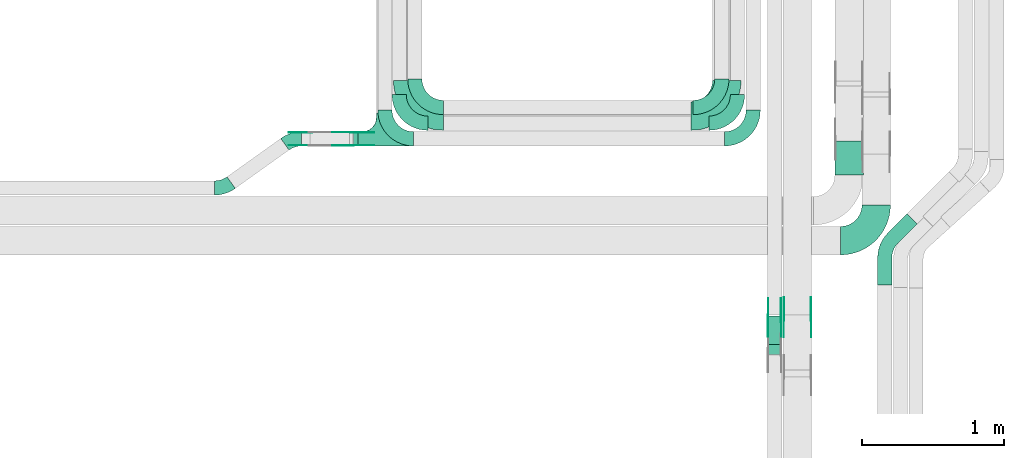
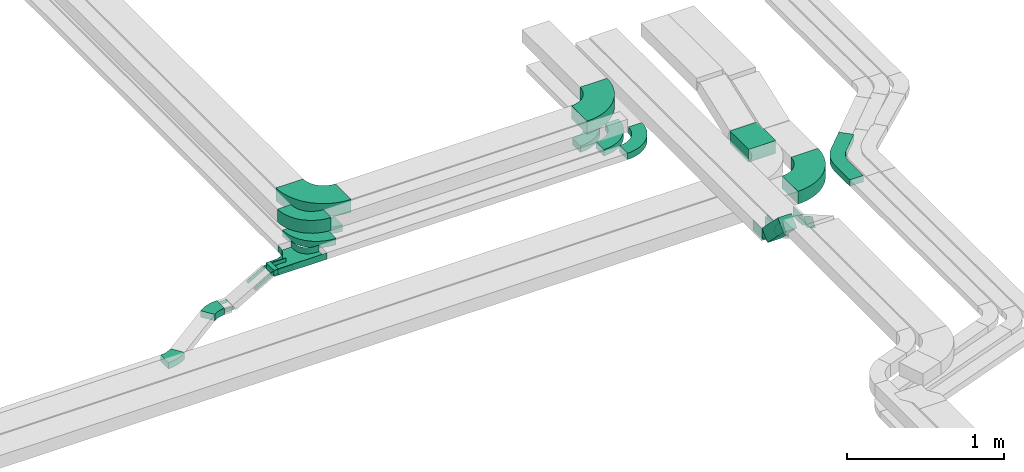
# One storey, part 20 of 23: 27 flow fittings, 3 flow segments.
"""IFC2X3 building model written with IfcOpenShell, lengths in millimetres."""

from ifc_helpers import new_model, entity, si_unit, converted_unit, derived_unit, direction, frame, frame_2d, origin, origin_2d_with_axis, place, context, subcontext, project, spatial, polyline, circle_curve, parameter, trimmed, segment, composite_curve, rectangle, outline, extrude, faceted_brep, source, transform, mapped, material, type_object, type_shapes, element, save


model = new_model("IFC2X3")

# Units and contexts
model_context = context("Model", 3, precision=0.01, world=origin(), true_north=direction((6.12303176911189e-17, 1.0)))
body_context = subcontext(model_context, "Body", "Model", "MODEL_VIEW")
ifc_project = project(units=[si_unit("LENGTHUNIT", "METRE", prefix="MILLI"), si_unit("AREAUNIT", "SQUARE_METRE"), si_unit("VOLUMEUNIT", "CUBIC_METRE"), converted_unit("PLANEANGLEUNIT", "DEGREE", entity("IfcRatioMeasure", 0.0174532925199433), si_unit("PLANEANGLEUNIT", "RADIAN"), dimensions=[0, 0, 0, 0, 0, 0, 0]), si_unit("MASSUNIT", "GRAM", prefix="KILO"), derived_unit("MASSDENSITYUNIT", [(si_unit("MASSUNIT", "GRAM", prefix="KILO"), 1), (si_unit("LENGTHUNIT", "METRE"), -3)]), derived_unit("MOMENTOFINERTIAUNIT", [(si_unit("LENGTHUNIT", "METRE"), 4)]), si_unit("TIMEUNIT", "SECOND"), si_unit("FREQUENCYUNIT", "HERTZ"), si_unit("THERMODYNAMICTEMPERATUREUNIT", "DEGREE_CELSIUS"), derived_unit("THERMALTRANSMITTANCEUNIT", [(si_unit("MASSUNIT", "GRAM", prefix="KILO"), 1), (si_unit("THERMODYNAMICTEMPERATUREUNIT", "KELVIN"), -1), (si_unit("TIMEUNIT", "SECOND"), -3)]), derived_unit("VOLUMETRICFLOWRATEUNIT", [(si_unit("LENGTHUNIT", "METRE"), 3), (si_unit("TIMEUNIT", "SECOND"), -1)]), derived_unit("MASSFLOWRATEUNIT", [(si_unit("MASSUNIT", "GRAM", prefix="KILO"), 1), (si_unit("TIMEUNIT", "SECOND"), -1)]), derived_unit("ROTATIONALFREQUENCYUNIT", [(si_unit("TIMEUNIT", "SECOND"), -1)]), si_unit("ELECTRICCURRENTUNIT", "AMPERE"), si_unit("ELECTRICVOLTAGEUNIT", "VOLT"), si_unit("POWERUNIT", "WATT"), si_unit("FORCEUNIT", "NEWTON", prefix="KILO"), si_unit("ILLUMINANCEUNIT", "LUX"), si_unit("LUMINOUSFLUXUNIT", "LUMEN"), si_unit("LUMINOUSINTENSITYUNIT", "CANDELA"), derived_unit("USERDEFINED", [(si_unit("MASSUNIT", "GRAM", prefix="KILO"), -1), (si_unit("LENGTHUNIT", "METRE"), -2), (si_unit("TIMEUNIT", "SECOND"), 3), (si_unit("LUMINOUSFLUXUNIT", "LUMEN"), 1)]), derived_unit("LINEARVELOCITYUNIT", [(si_unit("LENGTHUNIT", "METRE"), 1), (si_unit("TIMEUNIT", "SECOND"), -1)]), si_unit("PRESSUREUNIT", "PASCAL"), derived_unit("USERDEFINED", [(si_unit("LENGTHUNIT", "METRE"), -2), (si_unit("MASSUNIT", "GRAM", prefix="KILO"), 1), (si_unit("TIMEUNIT", "SECOND"), -2)]), derived_unit("LINEARFORCEUNIT", [(si_unit("MASSUNIT", "GRAM", prefix="KILO"), 1), (si_unit("LENGTHUNIT", "METRE"), 1), (si_unit("TIMEUNIT", "SECOND"), -2), (si_unit("LENGTHUNIT", "METRE"), -1)]), derived_unit("PLANARFORCEUNIT", [(si_unit("MASSUNIT", "GRAM", prefix="KILO"), 1), (si_unit("LENGTHUNIT", "METRE"), 1), (si_unit("TIMEUNIT", "SECOND"), -2), (si_unit("LENGTHUNIT", "METRE"), -2)])], contexts=[model_context])

# Site, building, storey
site_placement = place(None, origin())
site = spatial("IfcSite", under=ifc_project, at=site_placement, CompositionType="ELEMENT")
building_placement = place(site_placement, origin())
building = spatial("IfcBuilding", under=site, at=building_placement, CompositionType="ELEMENT")
storey_placement = place(building_placement, frame((0.0, 0.0, 24000.0)))
storey = spatial("IfcBuildingStorey", under=building, at=storey_placement, CompositionType="ELEMENT", Elevation=24000.0)

# Flow segments
cable_carrier_segment_type = type_object("IfcCableCarrierSegmentType", PredefinedType="CABLETRAYSEGMENT")
flow_segment_1_placement = place(storey_placement, frame((64748.84, 9500.0, 2972.83)))
element("IfcFlowSegment", 1, at=flow_segment_1_placement, inside=storey, type_object=cable_carrier_segment_type, context=body_context, shape_type="SweptSolid", body=[
    extrude(rectangle(XDim=31.2393327962174, YDim=100.000000000001, at=origin_2d_with_axis()), frame((15.62, 50.0, 0.0), z_axis=(0.0, 0.0, 1.0), x_axis=(-1.0, 0.0, 0.0)), (0.0, 0.0, 1.0), 49.9999999999973),
])
flow_segment_2_placement = place(storey_placement, frame((67656.35, 8034.48, 2986.44)))
element("IfcFlowSegment", 2, at=flow_segment_2_placement, inside=storey, type_object=cable_carrier_segment_type, context=body_context, shape_type="SweptSolid", body=[
    extrude(rectangle(XDim=100.000000000001, YDim=99.9999999999946, at=frame_2d((0.0, 0.0), x_axis=(0.0, 1.0))), frame((50.0, 237.93, 35.36), z_axis=(0.0, -0.70710678118652, 0.707106781186575), x_axis=(1.0, 0.0, 0.0)), (0.0, 0.0, 1.0), 286.484201246877),
])
flow_segment_3_placement = place(storey_placement, frame((68128.7, 9295.99, 2805.0)))
element("IfcFlowSegment", 3, at=flow_segment_3_placement, inside=storey, type_object=cable_carrier_segment_type, context=body_context, shape_type="SweptSolid", body=[
    extrude(rectangle(XDim=238.258949212567, YDim=200.000000000007, at=origin_2d_with_axis()), frame((100.0, 119.13, 0.0), z_axis=(0.0, 0.0, 1.0), x_axis=(0.0, 1.0, 0.0)), (0.0, 0.0, 1.0), 100.000000000003),
])

# Flow fittings
ifc_material_1 = material()
cable_carrier_fitting_type_1 = type_object("IfcCableCarrierFittingType", PredefinedType="NOTDEFINED", material=ifc_material_1)
shared_shape_1 = source(origin(), body_context, "Body", "Brep", [
    faceted_brep([(-53.41, -124.12, 25.0), (-50.0, -150.0, 25.0), (-50.0, -180.0, 25.0), (-49.2, -180.0, 25.0), (-49.2, -150.0, 25.0), (-52.63, -123.91, 25.0), (-62.7, -99.6, 25.0), (-78.72, -78.72, 25.0), (-99.6, -62.7, 25.0), (-123.91, -52.63, 25.0), (-150.0, -49.2, 25.0), (-180.0, -49.2, 25.0), (-180.0, -50.0, 25.0), (-150.0, -50.0, 25.0), (-124.12, -53.41, 25.0), (-100.0, -63.4, 25.0), (-79.29, -79.29, 25.0), (-63.4, -100.0, 25.0), (180.0, -50.0, 25.0), (180.0, -49.2, 25.0), (150.0, -49.2, 25.0), (123.91, -52.63, 25.0), (99.6, -62.7, 25.0), (78.72, -78.72, 25.0), (62.7, -99.6, 25.0), (52.63, -123.91, 25.0), (49.2, -150.0, 25.0), (49.2, -180.0, 25.0), (50.0, -180.0, 25.0), (50.0, -150.0, 25.0), (53.41, -124.12, 25.0), (63.4, -100.0, 25.0), (79.29, -79.29, 25.0), (100.0, -63.4, 25.0), (124.12, -53.41, 25.0), (150.0, -50.0, 25.0), (180.0, 49.2, 25.0), (180.0, 50.0, 25.0), (-180.0, 50.0, 25.0), (-180.0, 49.2, 25.0), (-180.0, -50.0, -25.0), (-180.0, 50.0, -25.0), (180.0, 50.0, -25.0), (180.0, -50.0, -25.0), (150.0, -50.0, -25.0), (124.12, -53.41, -25.0), (100.0, -63.4, -25.0), (79.29, -79.29, -25.0), (63.4, -100.0, -25.0), (53.41, -124.12, -25.0), (50.0, -150.0, -25.0), (50.0, -180.0, -25.0), (-50.0, -180.0, -25.0), (-50.0, -150.0, -25.0), (-53.41, -124.12, -25.0), (-63.4, -100.0, -25.0), (-79.29, -79.29, -25.0), (-100.0, -63.4, -25.0), (-124.12, -53.41, -25.0), (-150.0, -50.0, -25.0), (-50.0, -150.0, -24.2), (49.2, -180.0, -24.2), (-49.2, -180.0, -24.2), (-49.2, -150.0, -24.2), (-150.0, -49.2, -24.2), (-180.0, -49.2, -24.2), (180.0, -49.2, -24.2), (150.0, -49.2, -24.2), (-180.0, 49.2, -24.2), (-150.0, -50.0, -24.2), (150.0, -50.0, -24.2), (180.0, 49.2, -24.2), (49.2, -150.0, -24.2), (50.0, -150.0, -24.2), (-123.91, -52.63, -24.2), (-99.6, -62.7, -24.2), (-78.72, -78.72, -24.2), (-62.7, -99.6, -24.2), (-52.63, -123.91, -24.2), (52.63, -123.91, -24.2), (62.7, -99.6, -24.2), (78.72, -78.72, -24.2), (99.6, -62.7, -24.2), (123.91, -52.63, -24.2)], [[[0, 1, 2, 3, 4, 5, 6, 7, 8, 9, 10, 11, 12, 13, 14, 15, 16, 17]], [[18, 19, 20, 21, 22, 23, 24, 25, 26, 27, 28, 29, 30, 31, 32, 33, 34, 35]], [[36, 37, 38, 39]], [[40, 41, 42, 43, 44, 45, 46, 47, 48, 49, 50, 51, 52, 53, 54, 55, 56, 57, 58, 59]], [[2, 1, 60, 53, 52]], [[3, 2, 52, 51, 28, 27, 61, 62]], [[4, 3, 62, 63]], [[11, 10, 64, 65]], [[20, 19, 66, 67]], [[39, 38, 41, 40, 12, 11, 65, 68]], [[13, 12, 40, 59, 69]], [[18, 35, 70, 44, 43]], [[19, 18, 43, 42, 37, 36, 71, 66]], [[27, 26, 72, 61]], [[29, 28, 51, 50, 73]], [[38, 37, 42, 41]], [[36, 39, 68, 71]], [[68, 65, 64, 74, 75, 76, 77, 78, 63, 62, 61, 72, 79, 80, 81, 82, 83, 67, 66, 71]], [[14, 13, 69, 59, 58]], [[58, 57, 15, 14]], [[15, 57, 56, 16]], [[0, 17, 55, 54]], [[0, 54, 53, 60, 1]], [[55, 17, 16, 56]], [[5, 4, 63, 78]], [[6, 5, 78, 77]], [[7, 6, 77, 76]], [[8, 7, 76, 75]], [[9, 8, 75, 74]], [[10, 9, 74, 64]], [[21, 20, 67, 83]], [[22, 21, 83, 82]], [[23, 22, 82, 81]], [[81, 80, 24, 23]], [[24, 80, 79, 25]], [[79, 72, 26, 25]], [[30, 29, 73, 50, 49]], [[31, 30, 49, 48]], [[31, 48, 47, 32]], [[33, 32, 47, 46]], [[45, 34, 33, 46]], [[34, 45, 44, 70, 35]]]),
])
type_shapes(cable_carrier_fitting_type_1, [shared_shape_1])
flow_fitting_1_placement = place(storey_placement, frame((64960.08, 9550.0, 2997.83), z_axis=(0.0, 0.0, 1.0), x_axis=(-1.0, 0.0, 0.0)))
element("IfcFlowFitting", 4, at=flow_fitting_1_placement, inside=storey, type_object=cable_carrier_fitting_type_1, material=ifc_material_1, Name="470_DKC_S5_T", context=body_context, shape_type="MappedRepresentation", body=[
    mapped(shared_shape_1, transform((0.0, 0.0, 0.0), scale=1.0)),
])
cable_carrier_fitting_type_2 = type_object("IfcCableCarrierFittingType", Name="470_DKC_S5_Variable Angle Elbow 0-45:-", PredefinedType="NOTDEFINED", material=ifc_material_1)
shared_shape_2 = source(origin(), body_context, "Body", "SweptSolid", [
    extrude(outline(composite_curve([segment(polyline([(-125.75, -225.25), (-124.75, -225.25)]), True, "CONTINUOUS"), segment(trimmed(circle_curve(frame_2d((-124.75, 124.75), x_axis=(0.0, -1.0)), 350.0), [parameter(0.0)], [parameter(90.0000000000001)], True, "PARAMETER"), True, "CONTINUOUS"), segment(polyline([(225.25, 124.75), (225.25, 125.75)]), True, "CONTINUOUS"), segment(polyline([(225.25, 125.75), (25.25, 125.75)]), True, "CONTINUOUS"), segment(polyline([(25.25, 125.75), (25.25, 124.75)]), True, "CONTINUOUS"), segment(trimmed(circle_curve(frame_2d((-124.75, 124.75), x_axis=(0.0, -1.0)), 150.0), [parameter(0.0)], [parameter(90.0000000000001)], True, "PARAMETER"), False, "CONTINUOUS"), segment(polyline([(-124.75, -25.25), (-125.75, -25.25)]), True, "CONTINUOUS"), segment(polyline([(-125.75, -25.25), (-125.75, -225.25)]), True, "CONTINUOUS")], self_intersect=False)), frame((-125.25, 125.25, -50.0)), (0.0, 0.0, 1.0), 100.0),
])
type_shapes(cable_carrier_fitting_type_2, [shared_shape_2])
flow_fitting_2_placement = place(storey_placement, frame((67370.08, 9710.0, 3237.83)))
element("IfcFlowFitting", 5, at=flow_fitting_2_placement, inside=storey, type_object=cable_carrier_fitting_type_2, material=ifc_material_1, Name="470_DKC_S5_Variable Angle Elbow 0-45:-", ObjectType="470_DKC_S5_Variable Angle Elbow 0-45:-", context=body_context, shape_type="MappedRepresentation", body=[
    mapped(shared_shape_2, transform((0.0, 0.0, 0.0), scale=1.0)),
])
flow_fitting_3_placement = place(storey_placement, frame((65130.08, 9710.0, 3237.83), z_axis=(0.0, 0.0, 1.0), x_axis=(0.0, -1.0, 0.0)))
element("IfcFlowFitting", 6, at=flow_fitting_3_placement, inside=storey, type_object=cable_carrier_fitting_type_2, material=ifc_material_1, Name="470_DKC_S5_Variable Angle Elbow 0-45:-", ObjectType="470_DKC_S5_Variable Angle Elbow 0-45:-", context=body_context, shape_type="MappedRepresentation", body=[
    mapped(shared_shape_2, transform((0.0, 0.0, 0.0), scale=1.0)),
])
flow_fitting_4_placement = place(storey_placement, frame((68419.24, 8834.99, 2855.0)))
element("IfcFlowFitting", 7, at=flow_fitting_4_placement, inside=storey, type_object=cable_carrier_fitting_type_2, material=ifc_material_1, Name="470_DKC_S5_Variable Angle Elbow 0-45:-", ObjectType="470_DKC_S5_Variable Angle Elbow 0-45:-", context=body_context, shape_type="MappedRepresentation", body=[
    mapped(shared_shape_2, transform((0.0, 0.0, 0.0), scale=1.0)),
])
cable_carrier_fitting_type_3 = type_object("IfcCableCarrierFittingType", Name="470_DKC_S5_Variable Angle Elbow 0-45:-", PredefinedType="NOTDEFINED", material=ifc_material_1)
shared_shape_3 = source(origin(), body_context, "Body", "SweptSolid", [
    extrude(outline(composite_curve([segment(polyline([(-100.75, -150.25), (-99.75, -150.25)]), True, "CONTINUOUS"), segment(trimmed(circle_curve(frame_2d((-99.75, 99.75), x_axis=(0.0, -1.0)), 250.0), [parameter(0.0)], [parameter(90.0000000000001)], True, "PARAMETER"), True, "CONTINUOUS"), segment(polyline([(150.25, 99.75), (150.25, 100.75)]), True, "CONTINUOUS"), segment(polyline([(150.25, 100.75), (50.25, 100.75)]), True, "CONTINUOUS"), segment(polyline([(50.25, 100.75), (50.25, 99.75)]), True, "CONTINUOUS"), segment(trimmed(circle_curve(frame_2d((-99.75, 99.75), x_axis=(0.0, -1.0)), 150.0), [parameter(0.0)], [parameter(90.0000000000001)], True, "PARAMETER"), False, "CONTINUOUS"), segment(polyline([(-99.75, -50.25), (-100.75, -50.25)]), True, "CONTINUOUS"), segment(polyline([(-100.75, -50.25), (-100.75, -150.25)]), True, "CONTINUOUS")], self_intersect=False)), frame((-100.25, 100.25, -25.0)), (0.0, 0.0, 1.0), 49.9999999999997),
])
type_shapes(cable_carrier_fitting_type_3, [shared_shape_3])
flow_fitting_5_placement = place(storey_placement, frame((65180.08, 9770.0, 2997.83), z_axis=(0.0, 0.0, 1.0), x_axis=(0.0, -1.0, 0.0)))
element("IfcFlowFitting", 8, at=flow_fitting_5_placement, inside=storey, type_object=cable_carrier_fitting_type_3, material=ifc_material_1, Name="470_DKC_S5_Variable Angle Elbow 0-45:-", ObjectType="470_DKC_S5_Variable Angle Elbow 0-45:-", context=body_context, shape_type="MappedRepresentation", body=[
    mapped(shared_shape_3, transform((0.0, 0.0, 0.0), scale=1.0)),
])
flow_fitting_6_placement = place(storey_placement, frame((67335.53, 9770.0, 2997.83)))
element("IfcFlowFitting", 9, at=flow_fitting_6_placement, inside=storey, type_object=cable_carrier_fitting_type_3, material=ifc_material_1, Name="470_DKC_S5_Variable Angle Elbow 0-45:-", ObjectType="470_DKC_S5_Variable Angle Elbow 0-45:-", context=body_context, shape_type="MappedRepresentation", body=[
    mapped(shared_shape_3, transform((0.0, 0.0, 0.0), scale=1.0)),
])
flow_fitting_7_placement = place(storey_placement, frame((65070.08, 9660.0, 2997.83), z_axis=(0.0, 0.0, 1.0), x_axis=(0.0, -1.0, 0.0)))
element("IfcFlowFitting", 10, at=flow_fitting_7_placement, inside=storey, type_object=cable_carrier_fitting_type_3, material=ifc_material_1, Name="470_DKC_S5_Variable Angle Elbow 0-45:-", ObjectType="470_DKC_S5_Variable Angle Elbow 0-45:-", context=body_context, shape_type="MappedRepresentation", body=[
    mapped(shared_shape_3, transform((0.0, 0.0, 0.0), scale=1.0)),
])
for number, where, name in (
    (11, (67445.53, 9660.0, 2997.83), "470_DKC_S5_Variable Angle Elbow 0-45:-"),
    (12, (67555.53, 9550.0, 2997.83), "470_DKC_S5_Variable Angle Elbow 0-45:-"),
):
    element("IfcFlowFitting", number, at=place(storey_placement, frame(where)), inside=storey, type_object=cable_carrier_fitting_type_3, material=ifc_material_1, Name=name, ObjectType="470_DKC_S5_Variable Angle Elbow 0-45:-", context=body_context, shape_type="MappedRepresentation", body=[
        mapped(shared_shape_3, transform((0.0, 0.0, 0.0), scale=1.0)),
    ])
ifc_material_2 = material(Name="G")
cable_carrier_fitting_type_4 = type_object("IfcCableCarrierFittingType", PredefinedType="NOTDEFINED", material=ifc_material_2)
shared_shape_4 = source(origin(), body_context, "Body", "SweptSolid", [
    extrude(outline(composite_curve([segment(trimmed(circle_curve(frame_2d((-44.59, 0.0), x_axis=(1.0, 0.0)), 12.5), [parameter(90.0000000000007)], [parameter(270.0)], True, "PARAMETER"), True, "CONTINUOUS"), segment(polyline([(-44.59, -12.5), (-33.09, -12.5)]), True, "CONTINUOUS"), segment(polyline([(-33.09, -12.5), (-31.23, -14.5)]), True, "CONTINUOUS"), segment(polyline([(-31.23, -14.5), (108.91, -14.5)]), True, "CONTINUOUS"), segment(polyline([(108.91, -14.5), (108.91, 14.5)]), True, "CONTINUOUS"), segment(polyline([(108.91, 14.5), (-31.23, 14.5)]), True, "CONTINUOUS"), segment(polyline([(-31.23, 14.5), (-33.09, 12.5)]), True, "CONTINUOUS"), segment(polyline([(-33.09, 12.5), (-44.59, 12.5)]), True, "CONTINUOUS")], self_intersect=False)), frame((44.59, 0.0, 0.0), z_axis=(0.0, 0.0, -1.0), x_axis=(1.0, 0.0, 0.0)), (0.0, 0.0, -1.0), 2.0),
])
type_shapes(cable_carrier_fitting_type_4, [shared_shape_4])
flow_fitting_8_placement = place(storey_placement, frame((64740.08, 9504.54, 2997.83), z_axis=(0.0, -1.0, 0.0), x_axis=(-0.866342460673953, 0.0, -0.499450438815904)))
element("IfcFlowFitting", 13, at=flow_fitting_8_placement, inside=storey, type_object=cable_carrier_fitting_type_4, material=ifc_material_2, context=body_context, shape_type="MappedRepresentation", body=[
    mapped(shared_shape_4, transform((0.0, 0.0, 0.0), scale=1.0)),
])
cable_carrier_fitting_type_5 = type_object("IfcCableCarrierFittingType", PredefinedType="NOTDEFINED", material=ifc_material_2)
type_shapes(cable_carrier_fitting_type_5, [shared_shape_4])
for number, where, z_axis, x_axis in (
    (14, (64740.08, 9593.46, 2997.83), (0.0, 1.0, 0.0), (1.0, 0.0, 0.0)),
    (15, (64448.97, 9593.46, 2830.0), (0.0, 1.0, 0.0), (-1.0, 0.0, 0.0)),
):
    element("IfcFlowFitting", number, at=place(storey_placement, frame(where, z_axis=z_axis, x_axis=x_axis)), inside=storey, type_object=cable_carrier_fitting_type_5, material=ifc_material_2, context=body_context, shape_type="MappedRepresentation", body=[
        mapped(shared_shape_4, transform((0.0, 0.0, 0.0), scale=1.0)),
    ])
cable_carrier_fitting_type_6 = type_object("IfcCableCarrierFittingType", PredefinedType="NOTDEFINED", material=ifc_material_2)
shared_shape_5 = source(origin(), body_context, "Body", "SweptSolid", [
    extrude(outline(composite_curve([segment(trimmed(circle_curve(frame_2d((-44.59, 0.0), x_axis=(1.0, 0.0)), 12.5), [parameter(90.0000000000007)], [parameter(270.0)], True, "PARAMETER"), True, "CONTINUOUS"), segment(polyline([(-44.59, -12.5), (-33.09, -12.5)]), True, "CONTINUOUS"), segment(polyline([(-33.09, -12.5), (-31.23, -14.5)]), True, "CONTINUOUS"), segment(polyline([(-31.23, -14.5), (108.91, -14.5)]), True, "CONTINUOUS"), segment(polyline([(108.91, -14.5), (108.91, 14.5)]), True, "CONTINUOUS"), segment(polyline([(108.91, 14.5), (-31.23, 14.5)]), True, "CONTINUOUS"), segment(polyline([(-31.23, 14.5), (-33.09, 12.5)]), True, "CONTINUOUS"), segment(polyline([(-33.09, 12.5), (-44.59, 12.5)]), True, "CONTINUOUS")], self_intersect=False)), frame((44.59, 0.0, 0.0)), (0.0, 0.0, 1.0), 2.0),
])
type_shapes(cable_carrier_fitting_type_6, [shared_shape_5])
flow_fitting_9_placement = place(storey_placement, frame((64740.08, 9595.46, 2997.83), z_axis=(0.0, 1.0, 0.0), x_axis=(-0.866342460673953, 0.0, -0.499450438815904)))
element("IfcFlowFitting", 16, at=flow_fitting_9_placement, inside=storey, type_object=cable_carrier_fitting_type_6, material=ifc_material_2, context=body_context, shape_type="MappedRepresentation", body=[
    mapped(shared_shape_5, transform((0.0, 0.0, 0.0), scale=1.0)),
])
cable_carrier_fitting_type_7 = type_object("IfcCableCarrierFittingType", PredefinedType="NOTDEFINED", material=ifc_material_2)
type_shapes(cable_carrier_fitting_type_7, [shared_shape_5])
for number, where, z_axis, x_axis in (
    (17, (64740.08, 9506.54, 2997.83), (0.0, -1.0, 0.0), (1.0, 0.0, 0.0)),
    (18, (64448.97, 9506.54, 2830.0), (0.0, -1.0, 0.0), (-1.0, 0.0, 0.0)),
):
    element("IfcFlowFitting", number, at=place(storey_placement, frame(where, z_axis=z_axis, x_axis=x_axis)), inside=storey, type_object=cable_carrier_fitting_type_7, material=ifc_material_2, context=body_context, shape_type="MappedRepresentation", body=[
        mapped(shared_shape_5, transform((0.0, 0.0, 0.0), scale=1.0)),
    ])
cable_carrier_fitting_type_8 = type_object("IfcCableCarrierFittingType", Name="470_DKC_S5_Variable Angle Elbow 0-45:-", PredefinedType="NOTDEFINED", material=ifc_material_1)
shared_shape_6 = source(origin(), body_context, "Body", "SweptSolid", [
    extrude(outline(composite_curve([segment(polyline([(-100.75, -150.25), (-99.75, -150.25)]), True, "CONTINUOUS"), segment(trimmed(circle_curve(frame_2d((-99.75, 99.75), x_axis=(0.0, -1.0)), 250.0), [parameter(0.0)], [parameter(90.0000000000001)], True, "PARAMETER"), True, "CONTINUOUS"), segment(polyline([(150.25, 99.75), (150.25, 100.75)]), True, "CONTINUOUS"), segment(polyline([(150.25, 100.75), (50.25, 100.75)]), True, "CONTINUOUS"), segment(polyline([(50.25, 100.75), (50.25, 99.75)]), True, "CONTINUOUS"), segment(trimmed(circle_curve(frame_2d((-99.75, 99.75), x_axis=(0.0, -1.0)), 150.0), [parameter(0.0)], [parameter(90.0000000000001)], True, "PARAMETER"), False, "CONTINUOUS"), segment(polyline([(-99.75, -50.25), (-100.75, -50.25)]), True, "CONTINUOUS"), segment(polyline([(-100.75, -50.25), (-100.75, -150.25)]), True, "CONTINUOUS")], self_intersect=False)), frame((-100.25, 100.25, -50.0)), (0.0, 0.0, 1.0), 100.0),
])
type_shapes(cable_carrier_fitting_type_8, [shared_shape_6])
flow_fitting_10_placement = place(storey_placement, frame((64970.08, 9550.0, 3237.83), z_axis=(0.0, 0.0, 1.0), x_axis=(0.0, -1.0, 0.0)))
element("IfcFlowFitting", 19, at=flow_fitting_10_placement, inside=storey, type_object=cable_carrier_fitting_type_8, material=ifc_material_1, Name="470_DKC_S5_Variable Angle Elbow 0-45:-", ObjectType="470_DKC_S5_Variable Angle Elbow 0-45:-", context=body_context, shape_type="MappedRepresentation", body=[
    mapped(shared_shape_6, transform((0.0, 0.0, 0.0), scale=1.0)),
])
cable_carrier_fitting_type_9 = type_object("IfcCableCarrierFittingType", PredefinedType="NOTDEFINED", material=ifc_material_2)
shared_shape_7 = source(origin(), body_context, "Body", "SweptSolid", [
    extrude(outline(composite_curve([segment(trimmed(circle_curve(frame_2d((-41.47, 0.0), x_axis=(1.0, 0.0)), 25.0), [parameter(90.0000000000007)], [parameter(270.0)], True, "PARAMETER"), True, "CONTINUOUS"), segment(polyline([(-41.47, -25.0), (-29.97, -25.0)]), True, "CONTINUOUS"), segment(polyline([(-29.97, -25.0), (-28.1, -38.5)]), True, "CONTINUOUS"), segment(polyline([(-28.1, -38.5), (99.53, -38.5)]), True, "CONTINUOUS"), segment(polyline([(99.53, -38.5), (99.53, 38.5)]), True, "CONTINUOUS"), segment(polyline([(99.53, 38.5), (-28.1, 38.5)]), True, "CONTINUOUS"), segment(polyline([(-28.1, 38.5), (-29.97, 25.0)]), True, "CONTINUOUS"), segment(polyline([(-29.97, 25.0), (-41.47, 25.0)]), True, "CONTINUOUS")], self_intersect=False)), frame((41.47, 0.0, 0.0), z_axis=(0.0, 0.0, -1.0), x_axis=(1.0, 0.0, 0.0)), (0.0, 0.0, -1.0), 2.0),
])
type_shapes(cable_carrier_fitting_type_9, [shared_shape_7])
flow_fitting_11_placement = place(storey_placement, frame((67770.89, 8298.28, 3005.27), z_axis=(-1.0, 0.0, 0.0), x_axis=(0.0, -0.866025403784327, 0.500000000000193)))
element("IfcFlowFitting", 20, at=flow_fitting_11_placement, inside=storey, type_object=cable_carrier_fitting_type_9, material=ifc_material_2, context=body_context, shape_type="MappedRepresentation", body=[
    mapped(shared_shape_7, transform((0.0, 0.0, 0.0), scale=1.0)),
])
cable_carrier_fitting_type_10 = type_object("IfcCableCarrierFittingType", PredefinedType="NOTDEFINED", material=ifc_material_2)
type_shapes(cable_carrier_fitting_type_10, [shared_shape_7])
flow_fitting_12_placement = place(storey_placement, frame((67959.81, 8298.28, 3005.27), z_axis=(1.0, 0.0, 0.0), x_axis=(0.0, 1.0, 0.0)))
element("IfcFlowFitting", 21, at=flow_fitting_12_placement, inside=storey, type_object=cable_carrier_fitting_type_10, material=ifc_material_2, context=body_context, shape_type="MappedRepresentation", body=[
    mapped(shared_shape_7, transform((0.0, 0.0, 0.0), scale=1.0)),
])
flow_fitting_13_placement = place(storey_placement, frame((67660.89, 8288.93, 3005.27), z_axis=(-1.0, 0.0, 0.0), x_axis=(0.0, -0.707106781186429, 0.707106781186666)))
element("IfcFlowFitting", 22, at=flow_fitting_13_placement, inside=storey, type_object=cable_carrier_fitting_type_9, material=ifc_material_2, context=body_context, shape_type="MappedRepresentation", body=[
    mapped(shared_shape_7, transform((0.0, 0.0, 0.0), scale=1.0)),
])
flow_fitting_14_placement = place(storey_placement, frame((67749.81, 8288.93, 3005.27), z_axis=(1.0, 0.0, 0.0), x_axis=(0.0, 1.0, 0.0)))
element("IfcFlowFitting", 23, at=flow_fitting_14_placement, inside=storey, type_object=cable_carrier_fitting_type_10, material=ifc_material_2, context=body_context, shape_type="MappedRepresentation", body=[
    mapped(shared_shape_7, transform((0.0, 0.0, 0.0), scale=1.0)),
])
cable_carrier_fitting_type_11 = type_object("IfcCableCarrierFittingType", PredefinedType="NOTDEFINED", material=ifc_material_2)
shared_shape_8 = source(origin(), body_context, "Body", "SweptSolid", [
    extrude(outline(composite_curve([segment(trimmed(circle_curve(frame_2d((-41.47, 0.0), x_axis=(1.0, 0.0)), 25.0), [parameter(90.0000000000007)], [parameter(270.0)], True, "PARAMETER"), True, "CONTINUOUS"), segment(polyline([(-41.47, -25.0), (-29.97, -25.0)]), True, "CONTINUOUS"), segment(polyline([(-29.97, -25.0), (-28.1, -38.5)]), True, "CONTINUOUS"), segment(polyline([(-28.1, -38.5), (99.53, -38.5)]), True, "CONTINUOUS"), segment(polyline([(99.53, -38.5), (99.53, 38.5)]), True, "CONTINUOUS"), segment(polyline([(99.53, 38.5), (-28.1, 38.5)]), True, "CONTINUOUS"), segment(polyline([(-28.1, 38.5), (-29.97, 25.0)]), True, "CONTINUOUS"), segment(polyline([(-29.97, 25.0), (-41.47, 25.0)]), True, "CONTINUOUS")], self_intersect=False)), frame((41.47, 0.0, 0.0)), (0.0, 0.0, 1.0), 2.0),
])
type_shapes(cable_carrier_fitting_type_11, [shared_shape_8])
flow_fitting_15_placement = place(storey_placement, frame((67961.81, 8298.28, 3005.27), z_axis=(1.0, 0.0, 0.0), x_axis=(0.0, -0.866025403784327, 0.500000000000193)))
element("IfcFlowFitting", 24, at=flow_fitting_15_placement, inside=storey, type_object=cable_carrier_fitting_type_11, material=ifc_material_2, context=body_context, shape_type="MappedRepresentation", body=[
    mapped(shared_shape_8, transform((0.0, 0.0, 0.0), scale=1.0)),
])
cable_carrier_fitting_type_12 = type_object("IfcCableCarrierFittingType", PredefinedType="NOTDEFINED", material=ifc_material_2)
type_shapes(cable_carrier_fitting_type_12, [shared_shape_8])
flow_fitting_16_placement = place(storey_placement, frame((67772.89, 8298.28, 3005.27), z_axis=(-1.0, 0.0, 0.0), x_axis=(0.0, 1.0, 0.0)))
element("IfcFlowFitting", 25, at=flow_fitting_16_placement, inside=storey, type_object=cable_carrier_fitting_type_12, material=ifc_material_2, context=body_context, shape_type="MappedRepresentation", body=[
    mapped(shared_shape_8, transform((0.0, 0.0, 0.0), scale=1.0)),
])
flow_fitting_17_placement = place(storey_placement, frame((67751.81, 8288.93, 3005.27), z_axis=(1.0, 0.0, 0.0), x_axis=(0.0, -0.707106781186429, 0.707106781186666)))
element("IfcFlowFitting", 26, at=flow_fitting_17_placement, inside=storey, type_object=cable_carrier_fitting_type_11, material=ifc_material_2, context=body_context, shape_type="MappedRepresentation", body=[
    mapped(shared_shape_8, transform((0.0, 0.0, 0.0), scale=1.0)),
])
flow_fitting_18_placement = place(storey_placement, frame((67662.89, 8288.93, 3005.27), z_axis=(-1.0, 0.0, 0.0), x_axis=(0.0, 1.0, 0.0)))
element("IfcFlowFitting", 27, at=flow_fitting_18_placement, inside=storey, type_object=cable_carrier_fitting_type_12, material=ifc_material_2, context=body_context, shape_type="MappedRepresentation", body=[
    mapped(shared_shape_8, transform((0.0, 0.0, 0.0), scale=1.0)),
])
cable_carrier_fitting_type_13 = type_object("IfcCableCarrierFittingType", Name="470_DKC_S5_Variable Angle Elbow 0-45:-", PredefinedType="NOTDEFINED", material=ifc_material_1)
shared_shape_9 = source(origin(), body_context, "Body", "SweptSolid", [
    extrude(outline(composite_curve([segment(polyline([(-59.08, -68.77), (-58.08, -68.77)]), True, "CONTINUOUS"), segment(trimmed(circle_curve(frame_2d((-58.08, 181.23), x_axis=(0.0, -1.0)), 250.0), [parameter(0.0)], [parameter(35.5374827848269)], True, "PARAMETER"), True, "CONTINUOUS"), segment(polyline([(87.23, -22.21), (88.05, -21.62)]), True, "CONTINUOUS"), segment(polyline([(88.05, -21.62), (29.92, 59.75)]), True, "CONTINUOUS"), segment(polyline([(29.92, 59.75), (29.11, 59.17)]), True, "CONTINUOUS"), segment(trimmed(circle_curve(frame_2d((-58.08, 181.23), x_axis=(0.0, -1.0)), 150.0), [parameter(0.0)], [parameter(35.5374827848269)], True, "PARAMETER"), False, "CONTINUOUS"), segment(polyline([(-58.08, 31.23), (-59.08, 31.23)]), True, "CONTINUOUS"), segment(polyline([(-59.08, 31.23), (-59.08, -68.77)]), True, "CONTINUOUS")], self_intersect=False)), frame((-6.02, 18.77, -25.0)), (0.0, 0.0, 1.0), 50.0),
])
type_shapes(cable_carrier_fitting_type_13, [shared_shape_9])
flow_fitting_19_placement = place(storey_placement, frame((64320.48, 9550.0, 2830.0), z_axis=(0.0, 0.0, 1.0), x_axis=(-1.0, 0.0, 0.0)))
element("IfcFlowFitting", 28, at=flow_fitting_19_placement, inside=storey, type_object=cable_carrier_fitting_type_13, material=ifc_material_1, Name="470_DKC_S5_Variable Angle Elbow 0-45:-", ObjectType="470_DKC_S5_Variable Angle Elbow 0-45:-", context=body_context, shape_type="MappedRepresentation", body=[
    mapped(shared_shape_9, transform((0.0, 0.0, 0.0), scale=1.0)),
])
flow_fitting_20_placement = place(storey_placement, frame((63837.46, 9204.99, 2830.0)))
element("IfcFlowFitting", 29, at=flow_fitting_20_placement, inside=storey, type_object=cable_carrier_fitting_type_13, material=ifc_material_1, Name="470_DKC_S5_Variable Angle Elbow 0-45:-", ObjectType="470_DKC_S5_Variable Angle Elbow 0-45:-", context=body_context, shape_type="MappedRepresentation", body=[
    mapped(shared_shape_9, transform((0.0, 0.0, 0.0), scale=1.0)),
])
cable_carrier_fitting_type_14 = type_object("IfcCableCarrierFittingType", Name="470_DKC_S5_CS 90 internal vertical angle:-", PredefinedType="NOTDEFINED", material=ifc_material_1)
shared_shape_10 = source(origin(), body_context, "Body", "SweptSolid", [
    extrude(outline(composite_curve([segment(polyline([(-246.19, -112.76), (-56.85, -112.76)]), True, "CONTINUOUS"), segment(trimmed(circle_curve(frame_2d((-56.85, 137.24), x_axis=(0.0, -1.0)), 249.999999999999), [parameter(0.0)], [parameter(45.0)], True, "PARAMETER"), True, "CONTINUOUS"), segment(polyline([(119.93, -39.54), (253.81, 94.35)]), True, "CONTINUOUS"), segment(polyline([(253.81, 94.35), (183.1, 165.06)]), True, "CONTINUOUS"), segment(polyline([(183.1, 165.06), (49.22, 31.17)]), True, "CONTINUOUS"), segment(trimmed(circle_curve(frame_2d((-56.85, 137.24), x_axis=(0.0, -1.0)), 149.999999999999), [parameter(0.0)], [parameter(45.0)], True, "PARAMETER"), False, "CONTINUOUS"), segment(polyline([(-56.85, -12.76), (-246.19, -12.76)]), True, "CONTINUOUS"), segment(polyline([(-246.19, -12.76), (-246.19, -112.76)]), True, "CONTINUOUS")], self_intersect=False)), frame((-26.0, 62.76, -25.0)), (0.0, 0.0, 1.0), 49.9999999999999),
])
type_shapes(cable_carrier_fitting_type_14, [shared_shape_10])
flow_fitting_21_placement = place(storey_placement, frame((68479.09, 8796.1, 3004.67), z_axis=(0.00385230234690328, 0.00508717587948003, 0.999979639996835), x_axis=(-0.707092654053961, -0.707092654053894, 0.00632116808395283)))
element("IfcFlowFitting", 30, at=flow_fitting_21_placement, inside=storey, type_object=cable_carrier_fitting_type_14, material=ifc_material_1, Name="470_DKC_S5_CS 90 internal vertical angle:-", ObjectType="470_DKC_S5_CS 90 internal vertical angle:-", context=body_context, shape_type="MappedRepresentation", body=[
    mapped(shared_shape_10, transform((0.0, 0.0, 0.0), scale=1.0)),
])

save(model, "model.ifc")
